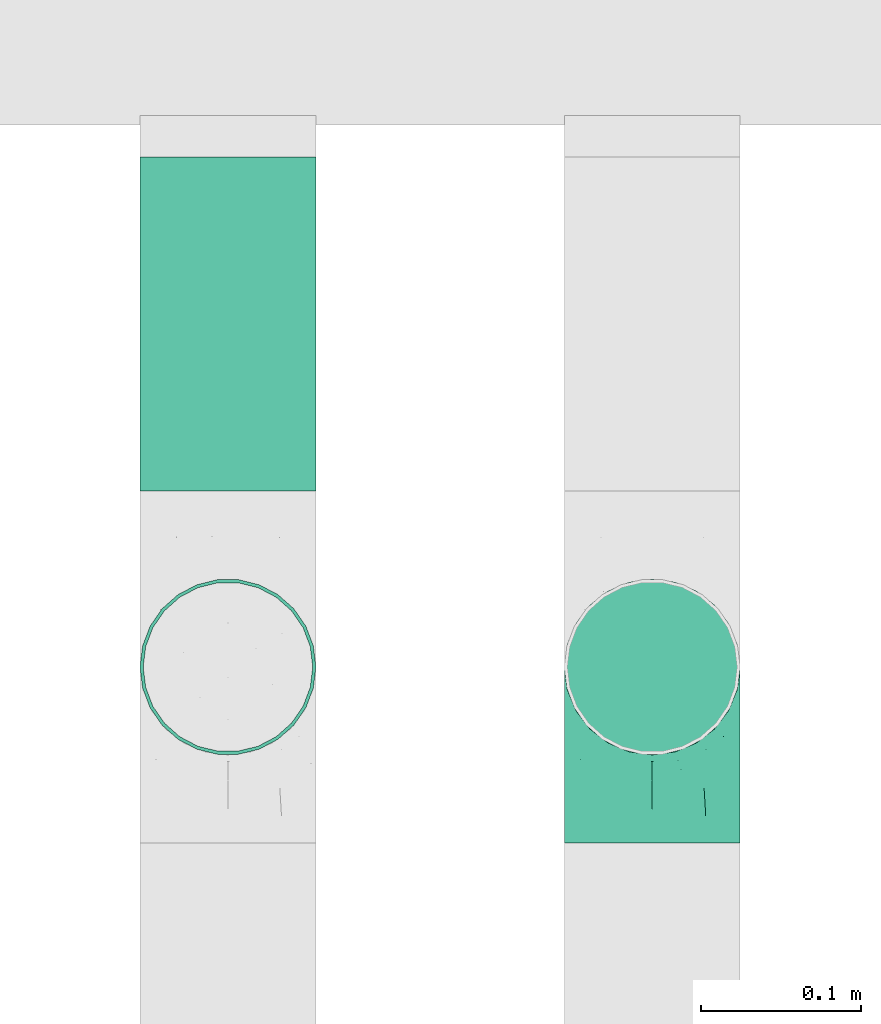
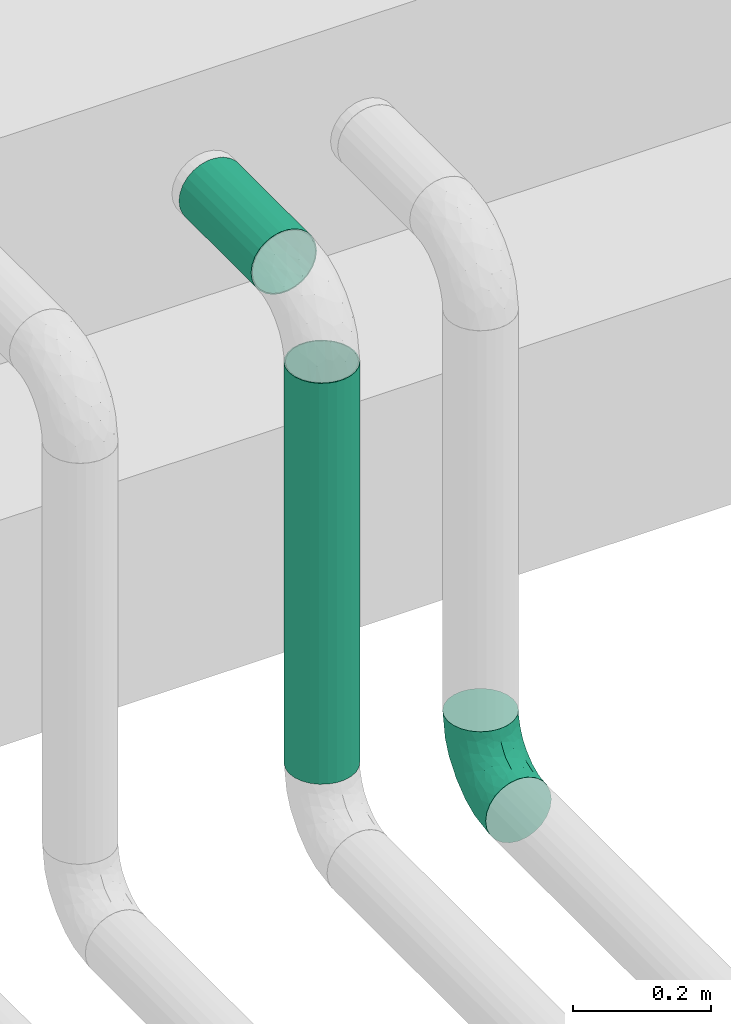
# One storey, part 26 of 91: 2 flow segments, 1 flow fitting.
"""IFC2X3 building model written with IfcOpenShell, lengths in millimetres."""

from ifc_helpers import new_model, entity, si_unit, converted_unit, derived_unit, direction, frame, origin_with_axes, origin_2d_with_axis, place, context, subcontext, project, spatial, hollow_circle, extrude, open_shell, surface_model, source, transform, mapped, material, layer, layer_set, layer_usage, type_object, element, save


model = new_model("IFC2X3")

# Units and contexts
model_context = context("Model", 3, precision=1e-05, world=origin_with_axes(), true_north=direction((0.0, 1.0)))
body_context = subcontext(model_context, "Body", "Model", "MODEL_VIEW")
ifc_project = project(units=[si_unit("AREAUNIT", "SQUARE_METRE"), si_unit("VOLUMEUNIT", "CUBIC_METRE", prefix="DECI"), si_unit("TIMEUNIT", "SECOND"), si_unit("THERMODYNAMICTEMPERATUREUNIT", "DEGREE_CELSIUS"), si_unit("PRESSUREUNIT", "PASCAL"), si_unit("MASSUNIT", "GRAM", prefix="KILO"), si_unit("LENGTHUNIT", "METRE", prefix="MILLI"), si_unit("POWERUNIT", "WATT"), si_unit("ELECTRICCURRENTUNIT", "AMPERE"), si_unit("ELECTRICVOLTAGEUNIT", "VOLT"), derived_unit("VOLUMETRICFLOWRATEUNIT", [(si_unit("VOLUMEUNIT", "CUBIC_METRE", prefix="DECI"), 1), (si_unit("TIMEUNIT", "SECOND"), -1)]), derived_unit("LINEARVELOCITYUNIT", [(si_unit("LENGTHUNIT", "METRE"), 1), (si_unit("TIMEUNIT", "SECOND"), -1)]), derived_unit("MASSDENSITYUNIT", [(si_unit("MASSUNIT", "GRAM", prefix="KILO"), 1), (si_unit("VOLUMEUNIT", "CUBIC_METRE"), -1)]), converted_unit("PLANEANGLEUNIT", "DEGREE", entity("IfcRatioMeasure", 0.01745), si_unit("PLANEANGLEUNIT", "RADIAN"), dimensions=[0, 0, 0, 0, 0, 0, 0])], contexts=[model_context])

# Site, building, storey
site_placement = place(None, origin_with_axes())
site = spatial("IfcSite", under=ifc_project, at=site_placement, CompositionType="ELEMENT")
building_placement = place(site_placement, origin_with_axes())
building = spatial("IfcBuilding", under=site, at=building_placement, Name="mc-building", CompositionType="ELEMENT")
storey_placement = place(building_placement, frame((0.0, 0.0, 8700.0), z_axis=(0.0, 0.0, 1.0), x_axis=(1.0, 0.0, 0.0)))
storey = spatial("IfcBuildingStorey", under=building, at=storey_placement, CompositionType="ELEMENT", Elevation=8700.0)

# Flow segments
ifc_material = material(Name="FZ1")
ifc_layer = layer(ifc_material, 0.0)
ifc_layer_set = layer_set([ifc_layer], Name="FZ1")
ifc_layer_usage = layer_usage(ifc_layer_set, "AXIS1", "POSITIVE", 0.0)
duct_segment_type = type_object("IfcDuctSegmentType", PredefinedType="RIGIDSEGMENT")
shared_shape_1 = source(origin_with_axes(), body_context, "Body", "SweptSolid", [
    extrude(hollow_circle(Radius=55.0, WallThickness=2.0, at=origin_2d_with_axis()), frame((0.0, 0.0, 0.0), z_axis=(1.0, 0.0, 0.0), x_axis=(0.0, 1.0, 0.0)), (0.0, 0.0, 1.0), 709.0),
])
flow_segment_1_placement = place(storey_placement, frame((16200.78197, 2612.35324, 1234.0), z_axis=(0.0, 1.0, 0.0), x_axis=(0.0, 0.0, -1.0)))
element("IfcFlowSegment", 1, at=flow_segment_1_placement, inside=storey, type_object=duct_segment_type, material=ifc_layer_usage, context=body_context, shape_type="MappedRepresentation", body=[
    mapped(shared_shape_1, transform((0.0, 0.0, 0.0), scale=1.0)),
])
shared_shape_2 = source(origin_with_axes(), body_context, "Body", "SweptSolid", [
    extrude(hollow_circle(Radius=55.0, WallThickness=2.0, at=origin_2d_with_axis()), frame((0.0, 0.0, 0.0), z_axis=(1.0, 0.0, 0.0), x_axis=(0.0, 1.0, 0.0)), (0.0, 0.0, 1.0), 208.9),
])
flow_segment_2_placement = place(storey_placement, frame((16200.78197, 2931.20513, 1344.0), z_axis=(0.0, 0.0, 1.0), x_axis=(0.0, -1.0, 0.0)))
element("IfcFlowSegment", 2, at=flow_segment_2_placement, inside=storey, type_object=duct_segment_type, material=ifc_layer_usage, context=body_context, shape_type="MappedRepresentation", body=[
    mapped(shared_shape_2, transform((0.0, 0.0, 0.0), scale=1.0, scale2=1.0, scale3=1.0, uniform=False)),
])

# Flow fitting
duct_fitting_type = type_object("IfcDuctFittingType", Name="BU", PredefinedType="BEND")
shared_shape_3 = source(origin_with_axes(), body_context, "Body", "SurfaceModel", [
    surface_model("IfcShellBasedSurfaceModel", [(-110.0, 0.0, -55.0), (-110.0, -14.23505, -53.12592), (-110.0, 14.23505, -53.12592), (-110.0, 53.12592, 14.23505), (-110.0, 27.5, -47.63139), (-110.0, 38.89087, -38.89087), (-110.0, -55.0, 0.0), (-110.0, -53.12592, 14.23505), (-110.0, -38.89087, -38.89087), (-110.0, -27.5, -47.63139), (-110.0, -53.12592, -14.23505), (-110.0, -47.63139, -27.5), (-110.0, -14.23505, 53.12592), (-110.0, 14.23505, 53.12592), (-110.0, 27.5, 47.63139), (-110.0, -47.63139, 27.5), (-110.0, -38.89087, 38.89087), (-110.0, -27.5, 47.63139), (-110.0, 0.0, 55.0), (-110.0, 55.0, 0.0), (-110.0, 53.12592, -14.23505), (-110.0, 47.63139, -27.5), (-110.0, 47.63139, 27.5), (-110.0, 38.89087, 38.89087), (-14.23505, 110.0, -53.12592), (-55.0, 110.0, 0.0), (0.0, 110.0, -55.0), (-27.5, 110.0, -47.63139), (-38.89087, 110.0, -38.89087), (-47.63139, 110.0, -27.5), (38.89087, 110.0, -38.89087), (53.12592, 110.0, 14.23505), (27.5, 110.0, -47.63139), (14.23505, 110.0, -53.12592), (47.63139, 110.0, -27.5), (53.12592, 110.0, -14.23505), (55.0, 110.0, 0.0), (-53.12592, 110.0, -14.23505), (-53.12592, 110.0, 14.23505), (-47.63139, 110.0, 27.5), (-38.89087, 110.0, 38.89087), (-27.5, 110.0, 47.63139), (0.0, 110.0, 55.0), (-14.23505, 110.0, 53.12592), (38.89087, 110.0, 38.89087), (47.63139, 110.0, 27.5), (27.5, 110.0, 47.63139), (14.23505, 110.0, 53.12592), (-64.21732, 48.68956, 43.63444), (-76.6405, 38.18013, 45.55988), (-60.44912, 32.56953, 51.94617), (-76.00813, 5.38378, 55.0), (-90.15553, 11.94394, 54.09138), (-78.5998, 26.77405, 50.81338), (-70.18771, 18.55163, 54.03432), (-75.55424, 54.2118, 32.41257), (-93.27622, 45.77614, 33.48188), (-96.12334, 22.13664, 50.81337), (-21.00813, 45.34362, 55.0), (-18.36258, 70.48427, 54.04484), (-32.04182, 59.64019, 52.24446), (-63.88653, 74.77858, 17.99134), (-74.66383, 63.08407, 19.92123), (-63.60674, 66.07878, 29.97482), (-99.597, 52.72185, 18.52927), (-93.11138, 56.59448, 10.50359), (-98.21577, 57.34403, 0.0), (-53.42855, 92.60092, 21.04759), (-88.54852, 54.8376, 21.04759), (-11.86161, 90.23965, 54.10313), (-5.38378, 76.00813, 55.0), (-57.34403, 98.21577, 0.0), (-56.64619, 93.12774, 10.22088), (-45.34362, 21.00813, 55.0), (-44.60838, 44.60838, 52.13415), (-92.68484, 35.46673, 43.63443), (-22.25266, 95.40765, 50.81337), (-35.97783, 90.61597, 43.63443), (-43.70931, 69.58671, 44.47149), (-27.23711, 77.39884, 50.81337), (-57.2828, 79.3123, 24.9774), (-58.67786, 84.31125, 16.04456), (-82.93277, 60.36161, 12.91784), (-49.88337, 54.51816, 47.224), (-74.57753, 66.83759, 9.55742), (-45.35812, 94.97281, 33.48188), (-59.18663, 88.95241, 0.0), (-51.517, 78.6292, 33.48188), (-65.14788, 80.03077, 0.0), (-56.45322, 62.06476, 39.63545), (-88.95241, 59.18663, 0.0), (-71.10913, 71.10913, 0.0), (-80.03077, 65.14788, 0.0), (-94.9309, 45.36788, -33.48188), (-93.11358, 56.60141, -10.46614), (-99.64997, 52.79499, -18.30015), (-90.20425, 36.08686, -43.63443), (-79.99933, 46.56772, -37.92748), (-76.00813, 5.38378, -55.0), (-72.75364, 19.68651, -53.60527), (-45.34362, 21.00813, -55.0), (-21.91957, 65.12078, -53.85897), (-5.38378, 76.00813, -55.0), (-21.00813, 45.34362, -55.0), (-35.41876, 92.89265, -43.63443), (-91.10309, 11.02766, -54.21832), (-45.77614, 93.27622, -33.48188), (-90.50474, 23.21022, -50.81337), (-70.92854, 33.31794, -49.51754), (-78.52933, 63.35627, -11.73997), (-24.91508, 84.05606, -50.81337), (-88.78941, 54.74452, -21.04759), (-69.59921, 57.34866, -33.48187), (-73.36422, 62.46673, -22.94182), (-63.49062, 67.59111, -28.46929), (-56.59448, 93.11138, -10.50359), (-54.8376, 88.54852, -21.04759), (-54.10679, 75.85581, -32.31867), (-57.75956, 31.09612, -52.80882), (-52.72185, 99.597, -18.52927), (-12.62913, 89.46304, -53.99097), (-34.46825, 66.46123, -50.04329), (-43.9837, 43.9837, -52.42279), (-65.78527, 72.58348, -17.68796), (-70.34468, 43.65295, -44.21951), (-57.47001, 51.99467, -44.91465), (-60.72547, 82.29174, -12.88567), (-42.34915, 74.24548, -43.63444), (-57.25194, 63.5016, -38.08211), (-80.95344, 53.56991, -29.32027), (-52.32891, 4.55257, -54.0482), (32.52942, 47.13398, -30.48571), (14.88266, 20.92917, -33.7947), (14.95561, 36.05775, -42.26543), (30.24048, 70.09027, -41.7461), (19.3559, 65.35825, -48.00507), (-70.35075, -46.44478, -19.5952), (-47.13398, -32.52942, -30.48571), (-28.49299, -30.5778, -16.4009), (-4.55257, 52.32891, -54.0482), (-22.4954, 22.4954, -53.25347), (-75.47368, -11.22546, -52.60718), (-81.32209, -51.5606, -9.98467), (-80.81763, -41.84862, -32.14655), (-70.09027, -30.24048, -41.7461), (-36.05774, -14.95561, -42.26543), (-9.15831, -10.852, -27.8997), (-65.35825, -19.3559, -48.00507), (11.22546, 75.47368, -52.60718), (3.94376, 43.9333, -50.53315), (-13.39742, 13.39743, -48.13058), (-43.9333, -3.94376, -50.53315), (49.37776, 67.29486, 0.0), (41.8609, 47.82256, -9.92641), (50.20582, 74.51695, -9.9731), (18.93131, 11.7156, -17.56239), (-27.5, -32.89419, 0.0), (-1.23348, -12.25375, -12.18106), (41.84862, 80.81763, -32.14655), (35.70604, 41.31408, -20.38235), (46.44478, 70.35075, -19.5952), (32.89419, 27.5, 0.0), (6.67262, -6.67262, 0.0), (-67.29486, -49.37776, 0.0), (-50.36265, -42.95545, -9.51562), (-5.47251, 5.47251, -39.92906), (-70.35075, -46.44478, 19.5952), (-74.51695, -50.20582, 9.9731), (-41.31407, -35.70604, 20.38235), (-47.13398, -32.52942, 30.48571), (-80.81763, -41.84862, 32.14655), (-4.55257, 52.32891, 54.0482), (11.22546, 75.47368, 52.60718), (-43.9333, -3.94376, 50.53315), (-65.35825, -19.3559, 48.00507), (-36.05774, -14.95561, 42.26543), (-70.09027, -30.24048, 41.7461), (-11.7156, -18.93131, 17.56239), (30.5778, 28.49299, 16.4009), (12.25375, 1.23348, 12.18106), (51.5606, 81.32209, 9.98467), (42.95545, 50.36265, 9.51562), (-75.47368, -11.22546, 52.60718), (-52.32891, 4.55257, 54.0482), (3.94376, 43.9333, 50.53315), (-22.4954, 22.4954, 53.25347), (-13.39742, 13.39743, 48.13058), (10.852, 9.15831, 27.8997), (-20.92916, -14.88266, 33.79469), (-47.82256, -41.8609, 9.92641), (32.52942, 47.13398, 30.48571), (46.44478, 70.35075, 19.5952), (41.84862, 80.81763, 32.14655), (30.24048, 70.09027, 41.7461), (19.3559, 65.35825, 48.00507), (14.95561, 36.05775, 42.26543), (-5.47251, 5.47251, 39.92906)], [open_shell([[[0, 1, 2]], [[2, 3, 4]], [[4, 3, 5]], [[2, 6, 7]], [[8, 6, 9]], [[1, 9, 6]], [[10, 6, 11]], [[8, 11, 6]], [[6, 2, 1]], [[12, 13, 14]], [[15, 2, 7]], [[16, 17, 2]], [[2, 17, 12]], [[12, 18, 13]], [[19, 20, 3]], [[5, 3, 21]], [[20, 21, 3]], [[22, 3, 2]], [[23, 22, 2]], [[12, 14, 2]], [[2, 14, 23]], [[15, 16, 2]], [[24, 25, 26]], [[27, 25, 24]], [[25, 28, 29]], [[28, 25, 27]], [[30, 26, 31]], [[26, 30, 32]], [[32, 33, 26]], [[34, 31, 35]], [[31, 34, 30]], [[35, 31, 36]], [[29, 37, 25]], [[38, 39, 26]], [[39, 40, 26]], [[41, 42, 40]], [[42, 26, 40]], [[42, 41, 43]], [[26, 44, 45]], [[31, 26, 45]], [[26, 46, 44]], [[47, 46, 26]], [[42, 47, 26]], [[25, 38, 26]], [[48, 49, 50]], [[18, 51, 52]], [[53, 54, 50]], [[55, 56, 49]], [[56, 22, 23]], [[13, 57, 14]], [[58, 59, 60]], [[61, 62, 63]], [[3, 64, 65]], [[53, 52, 54]], [[3, 65, 66]], [[67, 39, 38]], [[56, 68, 64]], [[65, 64, 68]], [[69, 59, 70]], [[38, 71, 72]], [[73, 58, 74]], [[75, 49, 56]], [[76, 69, 43]], [[53, 57, 52]], [[77, 78, 79]], [[41, 76, 43]], [[43, 69, 42]], [[55, 68, 56]], [[23, 14, 75]], [[76, 77, 79]], [[80, 67, 81]], [[62, 82, 68]], [[60, 78, 83]], [[62, 84, 82]], [[85, 77, 40]], [[81, 67, 72]], [[86, 72, 71]], [[87, 85, 67]], [[61, 81, 88]], [[77, 41, 40]], [[78, 77, 87]], [[23, 75, 56]], [[83, 89, 48]], [[85, 40, 39]], [[62, 68, 55]], [[89, 87, 63]], [[83, 48, 50]], [[57, 75, 14]], [[49, 75, 53]], [[67, 85, 39]], [[87, 77, 85]], [[63, 62, 55]], [[89, 55, 48]], [[80, 63, 87]], [[66, 65, 90]], [[66, 19, 3]], [[84, 91, 92]], [[92, 90, 82]], [[65, 82, 90]], [[61, 84, 62]], [[92, 82, 84]], [[68, 82, 65]], [[3, 22, 64]], [[56, 64, 22]], [[38, 25, 71]], [[81, 72, 86]], [[38, 72, 67]], [[91, 61, 88]], [[80, 81, 61]], [[63, 80, 61]], [[67, 80, 87]], [[77, 76, 41]], [[79, 59, 69]], [[79, 69, 76]], [[42, 69, 70]], [[60, 59, 79]], [[58, 70, 59]], [[78, 60, 79]], [[58, 60, 74]], [[52, 57, 13]], [[75, 57, 53]], [[18, 52, 13]], [[52, 51, 54]], [[51, 73, 54]], [[50, 73, 74]], [[73, 50, 54]], [[50, 74, 83]], [[60, 83, 74]], [[89, 83, 78]], [[87, 89, 78]], [[55, 89, 63]], [[50, 49, 53]], [[55, 49, 48]], [[81, 86, 88]], [[91, 84, 61]], [[5, 21, 93]], [[90, 94, 66]], [[20, 94, 95]], [[96, 93, 97]], [[98, 99, 100]], [[96, 4, 5]], [[101, 102, 103]], [[28, 27, 104]], [[2, 105, 0]], [[104, 106, 28]], [[99, 105, 107]], [[108, 107, 96]], [[90, 109, 94]], [[107, 2, 4]], [[20, 66, 94]], [[27, 24, 110]], [[109, 111, 94]], [[112, 113, 114]], [[37, 115, 71]], [[116, 106, 117]], [[99, 118, 100]], [[116, 115, 119]], [[37, 119, 115]], [[24, 120, 110]], [[121, 110, 101]], [[119, 106, 116]], [[101, 110, 120]], [[122, 103, 100]], [[117, 123, 116]], [[124, 125, 108]], [[115, 116, 126]], [[106, 29, 28]], [[26, 102, 120]], [[127, 104, 110]], [[97, 124, 96]], [[125, 122, 118]], [[128, 127, 125]], [[96, 5, 93]], [[115, 126, 86]], [[117, 106, 127]], [[111, 113, 129]], [[95, 93, 21]], [[97, 129, 112]], [[110, 104, 27]], [[106, 104, 127]], [[96, 107, 4]], [[99, 107, 108]], [[99, 108, 118]], [[105, 99, 98]], [[112, 114, 128]], [[121, 125, 127]], [[20, 19, 66]], [[109, 90, 92]], [[94, 111, 95]], [[91, 123, 109]], [[129, 113, 112]], [[93, 95, 111]], [[21, 20, 95]], [[71, 115, 86]], [[71, 25, 37]], [[123, 91, 88]], [[126, 116, 123]], [[123, 88, 126]], [[86, 126, 88]], [[37, 29, 119]], [[106, 119, 29]], [[129, 93, 111]], [[124, 112, 125]], [[0, 105, 98]], [[107, 105, 2]], [[125, 118, 108]], [[100, 118, 122]], [[93, 129, 97]], [[113, 111, 109]], [[109, 123, 113]], [[114, 123, 117]], [[123, 114, 113]], [[128, 114, 117]], [[127, 128, 117]], [[112, 128, 125]], [[103, 122, 101]], [[110, 121, 127]], [[101, 122, 121]], [[125, 121, 122]], [[26, 120, 24]], [[101, 120, 102]], [[96, 124, 108]], [[92, 91, 109]], [[112, 124, 97]], [[100, 130, 98]], [[131, 132, 133]], [[32, 134, 135]], [[136, 137, 138]], [[139, 140, 103]], [[98, 141, 0]], [[142, 10, 136]], [[143, 144, 137]], [[6, 10, 142]], [[137, 145, 146]], [[144, 147, 145]], [[143, 136, 11]], [[11, 136, 10]], [[8, 143, 11]], [[148, 149, 139]], [[8, 9, 144]], [[9, 1, 147]], [[130, 141, 98]], [[103, 140, 100]], [[148, 135, 149]], [[150, 151, 140]], [[152, 153, 154]], [[130, 140, 151]], [[148, 26, 33]], [[147, 1, 141]], [[155, 146, 132]], [[156, 138, 157]], [[134, 30, 158]], [[150, 140, 149]], [[158, 30, 34]], [[30, 134, 32]], [[153, 159, 160]], [[131, 160, 159]], [[144, 145, 137]], [[36, 152, 154]], [[146, 138, 137]], [[155, 161, 162]], [[158, 160, 131]], [[133, 149, 135]], [[156, 163, 164]], [[163, 142, 164]], [[139, 103, 102]], [[153, 152, 161]], [[34, 35, 160]], [[162, 157, 155]], [[132, 165, 133]], [[157, 146, 155]], [[140, 130, 100]], [[141, 130, 151]], [[141, 151, 147]], [[141, 1, 0]], [[102, 26, 148]], [[140, 139, 149]], [[102, 148, 139]], [[135, 33, 32]], [[151, 150, 145]], [[9, 147, 144]], [[151, 145, 147]], [[145, 165, 146]], [[135, 148, 33]], [[133, 135, 134]], [[131, 133, 134]], [[133, 165, 150]], [[133, 150, 149]], [[145, 150, 165]], [[132, 131, 159]], [[146, 165, 132]], [[160, 158, 34]], [[134, 158, 131]], [[144, 143, 8]], [[136, 143, 137]], [[155, 153, 161]], [[154, 153, 160]], [[153, 155, 159]], [[132, 159, 155]], [[160, 35, 154]], [[36, 154, 35]], [[164, 136, 138]], [[6, 142, 163]], [[136, 164, 142]], [[156, 164, 138]], [[156, 157, 162]], [[146, 157, 138]], [[15, 7, 166]], [[6, 163, 167]], [[168, 169, 166]], [[166, 169, 170]], [[171, 172, 70]], [[173, 174, 175]], [[17, 176, 174]], [[177, 156, 162]], [[176, 16, 170]], [[170, 16, 15]], [[161, 178, 179]], [[152, 180, 181]], [[182, 173, 183]], [[18, 12, 182]], [[184, 185, 186]], [[183, 185, 73]], [[183, 73, 51]], [[177, 187, 188]], [[189, 168, 166]], [[187, 178, 190]], [[16, 176, 17]], [[161, 152, 181]], [[45, 191, 31]], [[45, 44, 192]], [[192, 191, 45]], [[180, 36, 31]], [[193, 194, 195]], [[46, 47, 194]], [[193, 195, 190]], [[193, 44, 46]], [[172, 42, 70]], [[185, 58, 73]], [[189, 163, 156]], [[163, 189, 167]], [[70, 58, 171]], [[184, 171, 185]], [[169, 188, 175]], [[180, 31, 191]], [[192, 193, 190]], [[191, 190, 178]], [[182, 174, 173]], [[194, 47, 172]], [[190, 195, 187]], [[186, 185, 173]], [[162, 179, 177]], [[188, 196, 175]], [[179, 187, 177]], [[185, 171, 58]], [[172, 171, 184]], [[172, 184, 194]], [[172, 47, 42]], [[51, 18, 182]], [[185, 183, 173]], [[51, 182, 183]], [[174, 12, 17]], [[184, 186, 195]], [[46, 194, 193]], [[184, 195, 194]], [[195, 196, 187]], [[174, 182, 12]], [[175, 174, 176]], [[169, 175, 176]], [[175, 196, 186]], [[175, 186, 173]], [[195, 186, 196]], [[188, 169, 168]], [[187, 196, 188]], [[166, 170, 15]], [[176, 170, 169]], [[193, 192, 44]], [[191, 192, 190]], [[177, 189, 156]], [[167, 189, 166]], [[189, 177, 168]], [[188, 168, 177]], [[166, 7, 167]], [[6, 167, 7]], [[181, 191, 178]], [[36, 180, 152]], [[191, 181, 180]], [[161, 181, 178]], [[161, 179, 162]], [[187, 179, 178]]])]),
])
flow_fitting_placement = place(storey_placement, frame((16466.11947, 2612.35324, 415.0), z_axis=(1.0, 0.0, 0.0), x_axis=(0.0, 1.0, 0.0)))
element("IfcFlowFitting", 3, at=flow_fitting_placement, inside=storey, type_object=duct_fitting_type, Name="BU", context=body_context, shape_type="MappedRepresentation", body=[
    mapped(shared_shape_3, transform((0.0, 0.0, 0.0), scale=1.0)),
])

save(model, "model.ifc")
